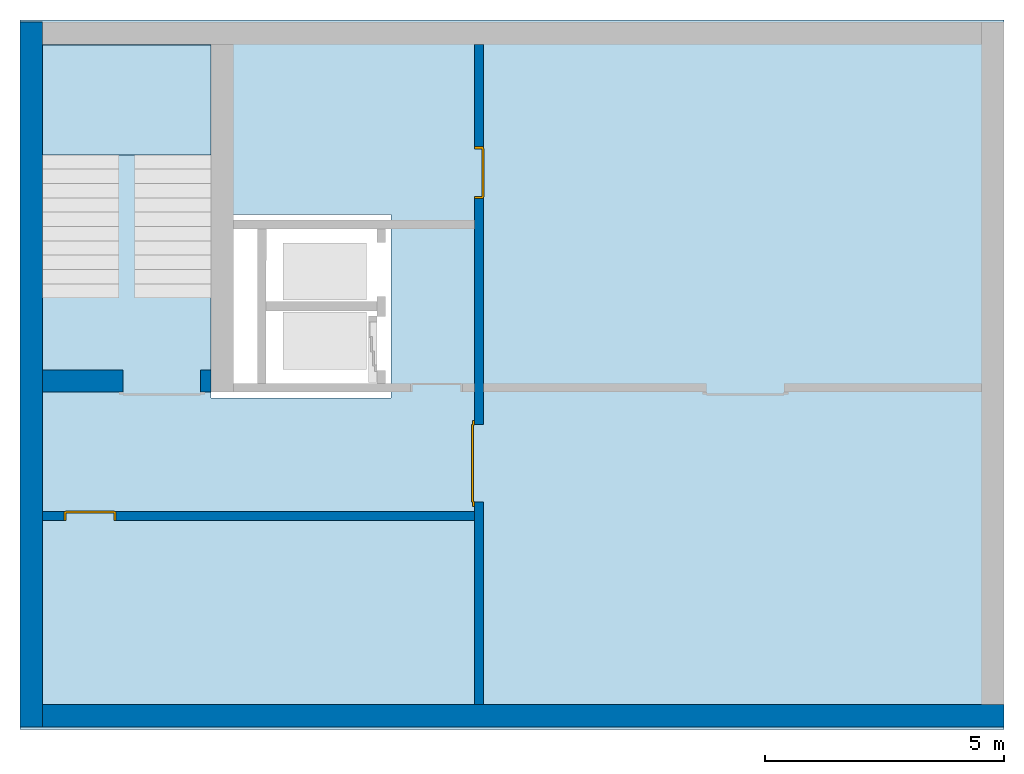
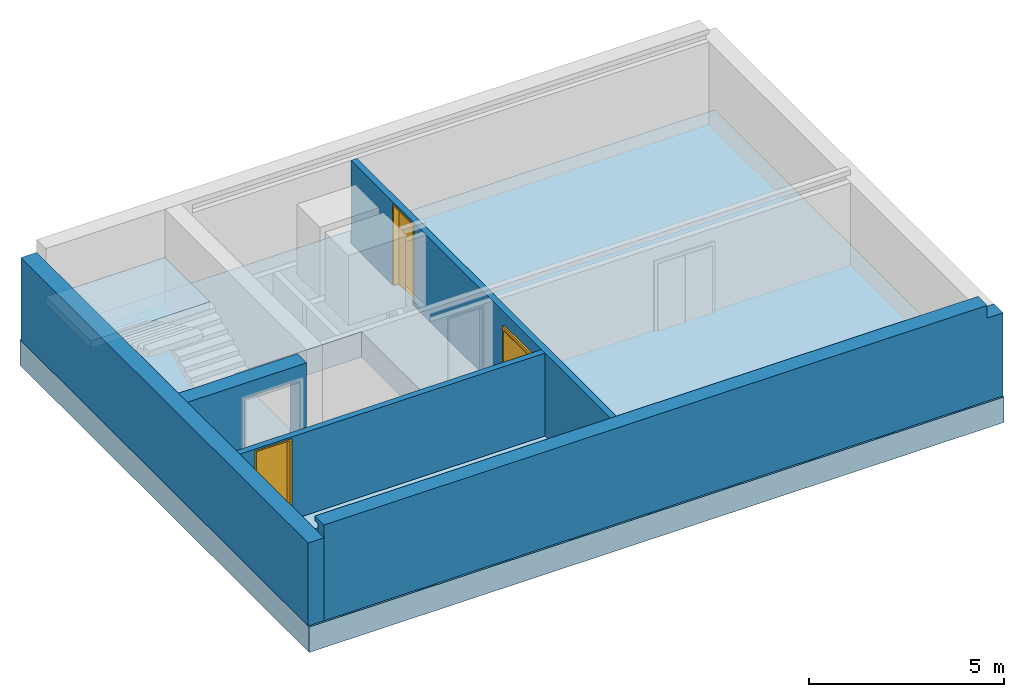
# One storey, part 1 of 5: 5 walls, 3 doors, 1 footing, 1 slab, 4 openings.
"""IFC4 building model written with IfcOpenShell, lengths in metres."""

from ifc_helpers import new_model, entity, si_unit, converted_unit, derived_unit, direction, frame, origin_with_axes, place, context, subcontext, project, spatial, polygons, source, transform, mapped, material, type_object, element, fill, save


model = new_model("IFC4")

# Units and contexts
model_context = context("Model", 3, precision=1e-05, world=origin_with_axes(), true_north=direction((0.0, 1.0)))
body_context = subcontext(model_context, "Body", "Model", "MODEL_VIEW")
ifc_project = project(units=[si_unit("LENGTHUNIT", "METRE"), si_unit("AREAUNIT", "SQUARE_METRE"), si_unit("VOLUMEUNIT", "CUBIC_METRE"), converted_unit("PLANEANGLEUNIT", "DEGREE", entity("IfcPlaneAngleMeasure", 0.0174532925199433), si_unit("PLANEANGLEUNIT", "RADIAN"), dimensions=[0, 0, 0, 0, 0, 0, 0]), converted_unit("TIMEUNIT", "Year", entity("IfcTimeMeasure", 31557600.0), si_unit("TIMEUNIT", "SECOND"), dimensions=[0, 0, 1, 0, 0, 0, 0]), si_unit("MASSUNIT", "GRAM", prefix="KILO"), si_unit("THERMODYNAMICTEMPERATUREUNIT", "DEGREE_CELSIUS"), si_unit("LUMINOUSINTENSITYUNIT", "LUMEN"), si_unit("ENERGYUNIT", "JOULE", prefix="MEGA"), derived_unit("THERMALCONDUCTANCEUNIT", [(si_unit("POWERUNIT", "WATT"), 1), (si_unit("LENGTHUNIT", "METRE"), -1), (si_unit("THERMODYNAMICTEMPERATUREUNIT", "KELVIN"), -1)]), derived_unit("SPECIFICHEATCAPACITYUNIT", [(si_unit("ENERGYUNIT", "JOULE"), 1), (si_unit("MASSUNIT", "GRAM", prefix="KILO"), -1), (si_unit("THERMODYNAMICTEMPERATUREUNIT", "KELVIN"), -1)]), derived_unit("MASSDENSITYUNIT", [(si_unit("MASSUNIT", "GRAM", prefix="KILO"), 1), (si_unit("VOLUMEUNIT", "CUBIC_METRE"), -1)])], contexts=[model_context])

# Site, building, storey
site_placement = place(None, origin_with_axes())
site = spatial("IfcSite", under=ifc_project, at=site_placement, CompositionType="ELEMENT")
building_placement = place(site_placement, origin_with_axes())
building = spatial("IfcBuilding", under=site, at=building_placement, CompositionType="ELEMENT")
storey_placement = place(building_placement, frame((0.0, 0.0, -3.0), z_axis=(0.0, 0.0, 1.0), x_axis=(1.0, 0.0, 0.0)))
storey = spatial("IfcBuildingStorey", under=building, at=storey_placement, Name="UG", CompositionType="ELEMENT", Elevation=-3.0)

# Footing
ifc_material_1 = material(Name="Stahlbeton Decke")
footing_type = type_object("IfcFootingType", Name="Stahlbeton Decke 800", PredefinedType="NOTDEFINED")
footing_placement = place(storey_placement, frame((44.584, 14.84599975347495, 0.0), z_axis=(0.0, 0.0, 1.0), x_axis=(1.0, 0.0, 0.0)))
element("IfcFooting", 1, at=footing_placement, inside=storey, type_object=footing_type, material=ifc_material_1, Name="Decke-001", PredefinedType="NOTDEFINED", context=body_context, shape_type="Tessellation", body=[
    polygons([(0.0, 0.0, 0.0), (0.0, 0.0, -0.7999999999999998), (-20.59599999999999, 0.0, -0.7999999999999998), (-20.59599999999999, 0.0, 0.0), (0.0, -14.84599975347495, 0.0), (0.0, -14.84599975347495, -0.7999999999999998), (-20.59599999999999, -14.84599975347495, -0.7999999999999998), (-12.82599999999999, -4.070999808007393, -0.7999999999999998), (-16.59599990856638, -4.070999808007393, -0.7999999999999998), (-16.59599990856638, -7.910999808007396, -0.7999999999999998), (-12.82599999999999, -7.910999808007396, -0.7999999999999998), (-20.59599999999999, -14.84599975347495, 0.0), (-16.59599990856638, -7.910999808007396, 0.0), (-16.59599990856638, -4.070999808007393, 0.0), (-12.82599999999999, -4.070999808007393, 0.0), (-12.82599999999999, -7.910999808007396, 0.0)], [[[1, 2, 3, 4]], [[5, 6, 2, 1]], [[3, 2, 6, 7], [8, 9, 10, 11]], [[4, 3, 7, 12]], [[5, 1, 4, 12], [13, 14, 15, 16]], [[12, 7, 6, 5]], [[14, 9, 8, 15]], [[13, 10, 9, 14]], [[16, 11, 10, 13]], [[15, 8, 11, 16]]], closed=True),
])

# Slab
ifc_material_2 = material(Name="Stahlbeton")
slab_type = type_object("IfcSlabType", Name="Stahlbeton 220", PredefinedType="LANDING")
slab_placement = place(storey_placement, frame((24.458, 12.02499994546755, 1.500000000000001), z_axis=(0.0, 0.0, 1.0), x_axis=(1.0, 0.0, 0.0)))
element("IfcSlab", 2, at=slab_placement, inside=storey, type_object=slab_type, material=ifc_material_2, Name="Decke-002", PredefinedType="LANDING", context=body_context, shape_type="Tessellation", body=[
    polygons([(0.0, 0.0, 0.0), (0.0, 0.0, -0.22), (3.530000000000001, 0.0, -0.22), (3.530000000000001, 0.0, 0.0), (0.0, 2.300999945467559, 0.0), (0.0, 2.300999945467559, -0.22), (3.530000000000001, 2.300999945467559, -0.22), (3.530000000000001, 2.300999945467559, 0.0)], [[[1, 2, 3, 4]], [[5, 6, 2, 1]], [[3, 2, 6, 7]], [[4, 3, 7, 8]], [[5, 1, 4, 8]], [[8, 7, 6, 5]]], closed=True),
])

# Walls
wall_type_1 = type_object("IfcWallType", Name="Stahlbeton 470", PredefinedType="NOTDEFINED")
wall_1_placement = place(storey_placement, frame((24.458, 0.5199999999999996, 0.0), z_axis=(0.0, 0.0, 1.0), x_axis=(1.0, 0.0, 0.0)))
element("IfcWall", 3, at=wall_1_placement, inside=storey, type_object=wall_type_1, material=ifc_material_2, Name="Wand-002", PredefinedType="NOTDEFINED", context=body_context, shape_type="Tessellation", body=[
    polygons([(19.656, -0.4699999999999989, 2.6), (19.656, -0.1569999999999991, 2.6), (19.656, -0.1569999999999991, 2.85), (19.656, 0.0, 2.85), (19.656, 0.0, 3.0), (19.656, -0.4699999999999989, 3.0), (20.126, 0.0, 2.6), (19.656, 0.0, 2.6), (20.126, -0.4699999999999989, 2.6), (0.0, -0.1569999999999991, 2.85), (0.0, -0.1569999999999991, 2.6), (0.0, 0.0, 2.85), (0.0, 0.0, 3.0), (0.0, -0.4699999999999998, 3.0), (0.0, -0.4699999999999998, 2.6), (0.0, -0.4699999999999998, 0.0), (20.126, -0.4699999999999989, 0.0), (0.0, 0.0, 0.0), (0.0, 0.0, 2.6), (20.126, 0.0, 0.0)], [[[1, 2, 3, 4, 5, 6]], [[7, 8, 2, 1, 9]], [[10, 3, 2, 11]], [[10, 12, 4, 3]], [[5, 4, 12, 13]], [[5, 13, 14, 6]], [[6, 14, 15, 16, 17, 9, 1]], [[18, 19, 8, 7, 20]], [[11, 2, 8, 19]], [[9, 17, 20, 7]], [[12, 10, 11, 15, 14, 13]], [[15, 11, 19, 18, 16]], [[20, 17, 16, 18]]], closed=True),
])
wall_2_placement = place(storey_placement, frame((24.458, 14.33186573724055, 0.0), z_axis=(0.0, 0.0, 1.0), x_axis=(0.0, -1.0, 0.0)))
element("IfcWall", 4, at=wall_2_placement, inside=storey, type_object=wall_type_1, material=ifc_material_2, Name="Wand-001", PredefinedType="NOTDEFINED", context=body_context, shape_type="Tessellation", body=[
    polygons([(14.28186573724055, -0.4699999999999989, 2.6), (14.28186573724055, 0.0, 2.6), (-0.4700000000000006, 0.0, 2.6), (-0.4699999999999989, -0.4699999999999989, 2.6), (14.28186573724055, -0.4699999999999989, 0.0), (14.28186573724055, 0.0, 0.0), (-0.4700000000000006, 0.0, 0.0), (-0.4699999999999989, -0.4699999999999989, 0.0)], [[[1, 2, 3, 4]], [[2, 1, 5, 6]], [[2, 6, 7, 3]], [[8, 4, 3, 7]], [[5, 1, 4, 8]], [[6, 5, 8, 7]]], closed=True),
])

# Wall, opening
wall_3_placement = place(storey_placement, frame((27.988, 7.054999945467554, 0.0), z_axis=(0.0, 0.0, 1.0), x_axis=(-1.0, 0.0, 0.0)))
wall_3 = element("IfcWall", 5, at=wall_3_placement, inside=storey, type_object=wall_type_1, material=ifc_material_2, Name="Wand-001", PredefinedType="NOTDEFINED", context=body_context, shape_type="Tessellation", body=[
    polygons([(1.839999999999996, -0.4700000000000006, 2.11), (1.839999999999996, -0.4699999999999998, 0.0), (3.530000000000001, -0.4700000000000006, 0.0), (3.530000000000001, -0.4699999999999998, 2.600000000000001), (0.0, -0.4699999999999998, 2.600000000000001), (0.0, -0.4699999999999998, 0.0), (0.2199999999999989, -0.4699999999999998, 0.0), (0.2199999999999989, -0.4700000000000006, 2.11), (1.839999999999996, 0.0, 2.11), (1.839999999999996, 0.0, 0.0), (3.530000000000001, 0.0, 0.0), (3.530000000000001, 0.0, 2.600000000000001), (0.0, 0.0, 2.600000000000001), (0.0, 0.0, 0.0), (0.2199999999999989, 0.0, 0.0), (0.2199999999999989, 0.0, 2.11)], [[[1, 2, 3, 4, 5, 6, 7, 8]], [[2, 1, 9, 10]], [[2, 10, 11, 3]], [[4, 3, 11, 12]], [[12, 13, 5, 4]], [[5, 13, 14, 6]], [[15, 7, 6, 14]], [[8, 7, 15, 16]], [[1, 8, 16, 9]], [[16, 15, 14, 13, 12, 11, 10, 9]]], closed=True),
])
opening_1_placement = place(wall_3_placement, frame((1.029999999999998, 0.0, 0.0), z_axis=(0.0, 0.0, 1.0), x_axis=(1.0, 0.0, 0.0)))
element("IfcOpeningElement", 6, at=opening_1_placement, cuts=wall_3, context=body_context, identifier="Reference", shape_type="Tessellation", body=[
    polygons([(-0.8099999999999987, -0.4710000000000001, 2.11), (-0.8099999999999987, -0.4710000000000001, 0.0), (0.8099999999999987, -0.4710000000000001, 0.0), (0.8099999999999987, -0.4710000000000001, 2.11), (-0.8099999999999987, 0.001000000000000334, 2.11), (-0.8099999999999987, 0.001000000000000334, 0.0), (0.8099999999999987, 0.001000000000000334, 0.0), (0.8099999999999987, 0.001000000000000334, 2.11)], [[[1, 2, 3, 4]], [[5, 6, 2, 1]], [[6, 7, 3, 2]], [[7, 8, 4, 3]], [[8, 5, 1, 4]], [[7, 6, 5, 8]]], closed=True),
])

# Wall, openings, doors
wall_type_2 = type_object("IfcWallType", Name="Stahlbeton 180", PredefinedType="NOTDEFINED")
wall_4_placement = place(storey_placement, frame((33.505, 14.33186573724055, 0.0), z_axis=(0.0, 0.0, 1.0), x_axis=(0.0, -1.0, 0.0)))
wall_4 = element("IfcWall", 7, at=wall_4_placement, inside=storey, type_object=wall_type_2, material=ifc_material_2, Name="Wand-001", PredefinedType="NOTDEFINED", context=body_context, shape_type="Tessellation", body=[
    polygons([(3.226865791772994, 0.1799999999999997, 0.0), (3.226865791772994, 0.1799999999999997, 2.545), (2.136865791772994, 0.1799999999999997, 2.545), (2.136865791772994, 0.1799999999999997, 0.0), (0.0, 0.1799999999999997, 0.0), (0.0, 0.1799999999999997, 2.599999999999998), (13.81186573724055, 0.1799999999999997, 2.599999999999998), (13.81186573724055, 0.1799999999999997, 0.0), (9.576865791772994, 0.1799999999999997, 0.0), (9.576865791772994, 0.1799999999999997, 2.11), (7.956865791772993, 0.1799999999999997, 2.11), (7.956865791772993, 0.1799999999999997, 0.0), (3.226865791772994, 0.0, 0.0), (3.226865791772994, 0.0, 2.545), (2.136865791772994, 0.0, 2.545), (2.136865791772994, 0.0, 0.0), (0.0, 0.0, 0.0), (0.0, 0.0, 2.599999999999998), (13.81186573724055, 0.0, 2.599999999999998), (13.81186573724055, 0.0, 0.0), (9.576865791772994, 0.0, 0.0), (9.576865791772994, 0.0, 2.11), (7.956865791772993, 0.0, 2.11), (7.956865791772993, 0.0, 0.0)], [[[1, 2, 3, 4, 5, 6, 7, 8, 9, 10, 11, 12]], [[2, 1, 13, 14]], [[3, 2, 14, 15]], [[4, 3, 15, 16]], [[4, 16, 17, 5]], [[17, 18, 6, 5]], [[6, 18, 19, 7]], [[7, 19, 20, 8]], [[9, 8, 20, 21]], [[9, 21, 22, 10]], [[10, 22, 23, 11]], [[11, 23, 24, 12]], [[13, 1, 12, 24]], [[14, 13, 24, 23, 22, 21, 20, 19, 18, 17, 16, 15]]], closed=True),
])
opening_2_placement = place(wall_4_placement, frame((8.766865791772993, 0.0, 0.0), z_axis=(0.0, 0.0, 1.0), x_axis=(1.0, 0.0, 0.0)))
opening_2 = element("IfcOpeningElement", 8, at=opening_2_placement, cuts=wall_4, context=body_context, identifier="Reference", shape_type="Tessellation", body=[
    polygons([(0.8100000000000005, 0.1809999999999974, 2.110000000000002), (0.8100000000000005, 0.1809999999999974, 0.0), (-0.8100000000000005, 0.1809999999999974, 0.0), (-0.8100000000000005, 0.1809999999999974, 2.110000000000002), (0.8100000000000005, -0.0009999999999976694, 2.110000000000002), (0.8100000000000005, -0.0009999999999976694, 0.0), (-0.8100000000000005, -0.0009999999999976694, 0.0), (-0.8100000000000005, -0.0009999999999976694, 2.110000000000002)], [[[1, 2, 3, 4]], [[5, 6, 2, 1]], [[6, 7, 3, 2]], [[7, 8, 4, 3]], [[8, 5, 1, 4]], [[7, 6, 5, 8]]], closed=True),
])
opening_3_placement = place(wall_4_placement, frame((2.681865791772994, 0.0, 0.0), z_axis=(0.0, 0.0, 1.0), x_axis=(1.0, 0.0, 0.0)))
opening_3 = element("IfcOpeningElement", 9, at=opening_3_placement, cuts=wall_4, context=body_context, identifier="Reference", shape_type="Tessellation", body=[
    polygons([(-0.5449999999999999, -0.0009999999999976694, 2.545000000000001), (-0.5449999999999999, -0.0009999999999976694, 0.0), (0.5449999999999999, -0.0009999999999976694, 0.0), (0.5449999999999999, -0.0009999999999976694, 2.545000000000001), (-0.5449999999999999, 0.1809999999999974, 2.545000000000001), (-0.5449999999999999, 0.1809999999999974, 0.0), (0.5449999999999999, 0.1809999999999974, 0.0), (0.5449999999999999, 0.1809999999999974, 2.545000000000001)], [[[1, 2, 3, 4]], [[5, 6, 2, 1]], [[6, 7, 3, 2]], [[7, 8, 4, 3]], [[8, 5, 1, 4]], [[7, 6, 5, 8]]], closed=True),
])
door_type_1 = type_object("IfcDoorType", OperationType="DOUBLE_DOOR_SINGLE_SWING", PredefinedType="DOOR")
shared_shape = source(origin_with_axes(), body_context, "Body", "Tessellation", [
    polygons([(-0.9000000000000001, 0.0, 0.0), (-0.9000000000000001, 0.0, 2.2), (-0.9000000000000001, 0.03, 2.2), (-0.9000000000000001, 0.03, 0.0), (-0.8000000000000002, 0.0, 0.0), (-0.8000000000000002, 0.0, 2.1), (-0.1101, 0.0, 2.1), (-0.0001, 0.0, 2.1), (0.8000000000000002, 0.0, 2.1), (0.8000000000000002, 0.0, 0.0), (0.9000000000000001, 0.0, 0.0), (0.9000000000000001, 0.0, 2.2), (0.9000000000000001, 0.03, 2.2), (0.9000000000000001, 0.03, 0.0), (0.8000000000000002, 0.03, 0.0), (0.8000000000000002, 0.03, 2.1), (-0.0001, 0.03, 2.1), (-0.1101, 0.03, 2.1), (-0.8000000000000002, 0.03, 2.1), (-0.8000000000000002, 0.03, 0.0)], [[[1, 2, 3, 4]], [[1, 5, 6, 7, 8, 9, 10, 11, 12, 2]], [[2, 12, 13, 3]], [[4, 3, 13, 14, 15, 16, 17, 18, 19, 20]], [[5, 1, 4, 20]], [[6, 5, 20, 19]], [[7, 6, 19, 18]], [[8, 7, 18, 17]], [[9, 8, 17, 16]], [[10, 9, 16, 15]], [[11, 10, 15, 14]], [[12, 11, 14, 13]]], closed=True),
    polygons([(-0.9000000000000001, 0.03, 0.0), (-0.9000000000000001, 0.03, 2.2), (-0.9000000000000001, 0.05, 2.2), (-0.9000000000000001, 0.05, 0.0), (-0.8100000000000002, 0.03, 0.0), (-0.8100000000000002, 0.03, 2.11), (-0.1001, 0.03, 2.11), (-0.0101, 0.03, 2.11), (0.8100000000000002, 0.03, 2.11), (0.8100000000000002, 0.03, 0.0), (0.9000000000000001, 0.03, 0.0), (0.9000000000000001, 0.03, 2.2), (0.9000000000000001, 0.05, 2.2), (0.9000000000000001, 0.05, 0.0), (0.8100000000000002, 0.05, 0.0), (0.8100000000000002, 0.05, 2.11), (-0.0101, 0.05, 2.11), (-0.1001, 0.05, 2.11), (-0.8100000000000002, 0.05, 2.11), (-0.8100000000000002, 0.05, 0.0)], [[[1, 2, 3, 4]], [[1, 5, 6, 7, 8, 9, 10, 11, 12, 2]], [[2, 12, 13, 3]], [[4, 3, 13, 14, 15, 16, 17, 18, 19, 20]], [[5, 1, 4, 20]], [[6, 5, 20, 19]], [[7, 6, 19, 18]], [[8, 7, 18, 17]], [[9, 8, 17, 16]], [[10, 9, 16, 15]], [[11, 10, 15, 14]], [[12, 11, 14, 13]]], closed=True),
    polygons([(-0.81, 0.07, 0.0), (-0.81, 0.07, 2.11), (-0.0004999999999999449, 0.07, 2.11), (-0.0004999999999999449, 0.07, 0.0), (-0.81, 0.03000000000000001, 0.0), (-0.81, 0.03000000000000001, 2.11), (-0.0004999999999999449, 0.03000000000000001, 2.11), (-0.0004999999999999449, 0.03000000000000001, 0.0)], [[[1, 2, 3, 4]], [[1, 5, 6, 2]], [[2, 6, 7, 3]], [[3, 7, 8, 4]], [[4, 8, 5, 1]], [[8, 7, 6, 5]]], closed=True),
    polygons([(0.81, 0.07, 0.0), (0.0004999999999999449, 0.07, 0.0), (0.0004999999999999449, 0.07, 2.11), (0.81, 0.07, 2.11), (0.81, 0.03000000000000001, 0.0), (0.0004999999999999449, 0.03000000000000001, 0.0), (0.0004999999999999449, 0.03000000000000001, 2.11), (0.81, 0.03000000000000001, 2.11)], [[[1, 2, 3, 4]], [[2, 1, 5, 6]], [[3, 2, 6, 7]], [[4, 3, 7, 8]], [[1, 4, 8, 5]], [[6, 5, 8, 7]]], closed=True),
])
door_1_placement = place(opening_2_placement, frame((0.7999999999999998, 0.0, 0.0), z_axis=(0.0, 0.0, 1.0), x_axis=(-1.0, 0.0, 0.0)))
door_1 = element("IfcDoor", 10, at=door_1_placement, inside=storey, type_object=door_type_1, OverallHeight=2.11, OverallWidth=1.62, PredefinedType="DOOR", context=body_context, shape_type="MappedRepresentation", body=[
    mapped(shared_shape, transform((0.7999999999999998, 0.0, 0.0))),
])
fill(opening_2, door_1)
door_type_2 = type_object("IfcDoorType", Name="27", OperationType="SINGLE_SWING_LEFT", PredefinedType="DOOR")
door_2_placement = place(opening_3_placement, frame((-0.5, 0.0, 0.0), z_axis=(0.0, 0.0, 1.0), x_axis=(1.0, 0.0, 0.0)))
door_2 = element("IfcDoor", 11, at=door_2_placement, inside=storey, type_object=door_type_2, OverallHeight=2.545, OverallWidth=1.09, PredefinedType="DOOR", context=body_context, shape_type="Tessellation", body=[
    polygons([(-0.04499999999999993, 0.0, 0.0), (-0.04499999999999993, 0.0, 2.545000000000001), (-0.04499999999999993, 0.1550000000000011, 2.545000000000001), (-0.04499999999999993, 0.1550000000000011, 0.0), (0.0, 0.0, 0.0), (0.0, 0.0, 2.500000000000001), (0.4449000000000005, 0.0, 2.500000000000001), (0.4999000000000002, 0.0, 2.500000000000001), (1.0, 0.0, 2.500000000000001), (1.0, 0.0, 0.0), (1.045, 0.0, 0.0), (1.045, 0.0, 2.545000000000001), (1.045, 0.1550000000000011, 2.545000000000001), (1.045, 0.1550000000000011, 0.0), (1.0, 0.1550000000000011, 0.0), (1.0, 0.1550000000000011, 2.500000000000001), (0.4999000000000002, 0.1550000000000011, 2.500000000000001), (0.4449000000000005, 0.1550000000000011, 2.500000000000001), (0.0, 0.1550000000000011, 2.500000000000001), (0.0, 0.1550000000000011, 0.0)], [[[1, 2, 3, 4]], [[1, 5, 6, 7, 8, 9, 10, 11, 12, 2]], [[2, 12, 13, 3]], [[4, 3, 13, 14, 15, 16, 17, 18, 19, 20]], [[5, 1, 4, 20]], [[6, 5, 20, 19]], [[7, 6, 19, 18]], [[8, 7, 18, 17]], [[9, 8, 17, 16]], [[10, 9, 16, 15]], [[11, 10, 15, 14]], [[12, 11, 14, 13]]], closed=True),
    polygons([(-0.04499999999999993, 0.1550000000000011, 0.0), (-0.04499999999999993, 0.1550000000000011, 2.545000000000001), (-0.04499999999999993, 0.1799999999999997, 2.545000000000001), (-0.04499999999999993, 0.1799999999999997, 0.0), (-0.009999999999999787, 0.1550000000000011, 0.0), (-0.009999999999999787, 0.1550000000000011, 2.510000000000001), (0.4549000000000003, 0.1550000000000011, 2.510000000000001), (0.4899000000000004, 0.1550000000000011, 2.510000000000001), (1.01, 0.1550000000000011, 2.510000000000001), (1.01, 0.1550000000000011, 0.0), (1.045, 0.1550000000000011, 0.0), (1.045, 0.1550000000000011, 2.545000000000001), (1.045, 0.1799999999999997, 2.545000000000001), (1.045, 0.1799999999999997, 0.0), (1.01, 0.1799999999999997, 0.0), (1.01, 0.1799999999999997, 2.510000000000001), (0.4899000000000004, 0.1799999999999997, 2.510000000000001), (0.4549000000000003, 0.1799999999999997, 2.510000000000001), (-0.009999999999999787, 0.1799999999999997, 2.510000000000001), (-0.009999999999999787, 0.1799999999999997, 0.0)], [[[1, 2, 3, 4]], [[1, 5, 6, 7, 8, 9, 10, 11, 12, 2]], [[2, 12, 13, 3]], [[4, 3, 13, 14, 15, 16, 17, 18, 19, 20]], [[5, 1, 4, 20]], [[6, 5, 20, 19]], [[7, 6, 19, 18]], [[8, 7, 18, 17]], [[9, 8, 17, 16]], [[10, 9, 16, 15]], [[11, 10, 15, 14]], [[12, 11, 14, 13]]], closed=True),
    polygons([(-0.009999999999999787, 0.1950000000000003, 0.0), (-0.009999999999999787, 0.1950000000000003, 2.510000000000001), (1.01, 0.1950000000000003, 2.510000000000001), (1.01, 0.1950000000000003, 0.0), (-0.009999999999999787, 0.1550000000000011, 0.0), (-0.009999999999999787, 0.1550000000000011, 2.510000000000001), (1.01, 0.1550000000000011, 2.510000000000001), (1.01, 0.1550000000000011, 0.0)], [[[1, 2, 3, 4]], [[1, 5, 6, 2]], [[2, 6, 7, 3]], [[3, 7, 8, 4]], [[4, 8, 5, 1]], [[8, 7, 6, 5]]], closed=True),
])
fill(opening_3, door_2)

# Wall, opening, door
wall_5_placement = place(storey_placement, frame((33.505, 4.554999945467554, 0.0), z_axis=(0.0, 0.0, 1.0), x_axis=(-1.0, 0.0, 0.0)))
wall_5 = element("IfcWall", 12, at=wall_5_placement, inside=storey, type_object=wall_type_2, material=ifc_material_2, Name="Wand-003", PredefinedType="NOTDEFINED", context=body_context, shape_type="Tessellation", body=[
    polygons([(8.596999999999994, 0.0, 2.545), (8.596999999999994, 0.0, 0.0), (9.046999999999997, 0.0, 0.0), (9.046999999999997, 0.0, 2.599999999999999), (0.0, 0.0, 2.599999999999999), (0.0, 0.0, 0.0), (7.506999999999998, 0.0, 0.0), (7.506999999999998, 0.0, 2.545), (8.596999999999994, 0.1799999999999997, 2.545), (8.596999999999994, 0.1799999999999997, 0.0), (9.046999999999997, 0.1799999999999997, 0.0), (9.046999999999997, 0.1799999999999997, 2.599999999999999), (0.0, 0.1800000000000006, 2.599999999999999), (0.0, 0.1799999999999997, 0.0), (7.506999999999998, 0.1799999999999997, 0.0), (7.506999999999998, 0.1799999999999997, 2.545)], [[[1, 2, 3, 4, 5, 6, 7, 8]], [[2, 1, 9, 10]], [[2, 10, 11, 3]], [[11, 12, 4, 3]], [[12, 13, 5, 4]], [[14, 6, 5, 13]], [[15, 7, 6, 14]], [[8, 7, 15, 16]], [[1, 8, 16, 9]], [[16, 15, 14, 13, 12, 11, 10, 9]]], closed=True),
])
opening_4_placement = place(wall_5_placement, frame((8.051999999999996, 0.0, 0.0), z_axis=(0.0, 0.0, 1.0), x_axis=(1.0, 0.0, 0.0)))
opening_4 = element("IfcOpeningElement", 13, at=opening_4_placement, cuts=wall_5, context=body_context, identifier="Reference", shape_type="Tessellation", body=[
    polygons([(-0.5449999999999982, -0.001000000000000334, 2.545000000000001), (-0.5449999999999982, -0.001000000000000334, 0.0), (0.5449999999999982, -0.001000000000000334, 0.0), (0.5449999999999982, -0.001000000000000334, 2.545000000000001), (-0.5449999999999982, 0.181, 2.545000000000001), (-0.5449999999999982, 0.181, 0.0), (0.5449999999999982, 0.181, 0.0), (0.5449999999999982, 0.181, 2.545000000000001)], [[[1, 2, 3, 4]], [[5, 6, 2, 1]], [[6, 7, 3, 2]], [[7, 8, 4, 3]], [[8, 5, 1, 4]], [[7, 6, 5, 8]]], closed=True),
])
door_3_placement = place(opening_4_placement, frame((0.5, 0.0, 0.0), z_axis=(0.0, 0.0, 1.0), x_axis=(-1.0, 0.0, 0.0)))
door_3 = element("IfcDoor", 14, at=door_3_placement, inside=storey, type_object=door_type_2, OverallHeight=2.545, OverallWidth=1.09, PredefinedType="DOOR", context=body_context, shape_type="Tessellation", body=[
    polygons([(-0.04499999999999815, -0.1799999999999988, 0.0), (-0.04499999999999815, -0.1799999999999988, 2.545000000000001), (-0.04499999999999815, -0.02499999999999947, 2.545000000000001), (-0.04499999999999815, -0.02499999999999858, 0.0), (0.0, -0.1799999999999988, 0.0), (0.0, -0.1799999999999988, 2.500000000000001), (0.4449000000000005, -0.1799999999999988, 2.500000000000001), (0.4999000000000002, -0.1799999999999988, 2.500000000000001), (1.0, -0.1799999999999997, 2.500000000000001), (1.0, -0.1799999999999988, 0.0), (1.044999999999998, -0.1799999999999988, 0.0), (1.044999999999998, -0.1799999999999997, 2.545000000000001), (1.044999999999998, -0.02499999999999947, 2.545000000000001), (1.044999999999998, -0.02499999999999947, 0.0), (1.0, -0.02499999999999947, 0.0), (1.0, -0.02499999999999947, 2.500000000000001), (0.4999000000000002, -0.02499999999999947, 2.500000000000001), (0.4449000000000005, -0.02499999999999947, 2.500000000000001), (0.0, -0.02499999999999947, 2.500000000000001), (0.0, -0.02499999999999858, 0.0)], [[[1, 2, 3, 4]], [[1, 5, 6, 7, 8, 9, 10, 11, 12, 2]], [[2, 12, 13, 3]], [[4, 3, 13, 14, 15, 16, 17, 18, 19, 20]], [[5, 1, 4, 20]], [[6, 5, 20, 19]], [[7, 6, 19, 18]], [[8, 7, 18, 17]], [[9, 8, 17, 16]], [[10, 9, 16, 15]], [[11, 10, 15, 14]], [[12, 11, 14, 13]]], closed=True),
    polygons([(-0.04499999999999815, -0.02499999999999858, 0.0), (-0.04499999999999815, -0.02499999999999947, 2.545000000000001), (-0.04499999999999815, 0.0, 2.545000000000001), (-0.04499999999999815, 0.0, 0.0), (-0.01000000000000156, -0.02499999999999858, 0.0), (-0.01000000000000156, -0.02499999999999947, 2.510000000000001), (0.4548999999999985, -0.02499999999999947, 2.510000000000001), (0.4898999999999987, -0.02499999999999947, 2.510000000000001), (1.010000000000002, -0.02499999999999947, 2.510000000000001), (1.010000000000002, -0.02499999999999947, 0.0), (1.044999999999998, -0.02499999999999947, 0.0), (1.044999999999998, -0.02499999999999947, 2.545000000000001), (1.044999999999998, 0.0, 2.545000000000001), (1.044999999999998, 0.0, 0.0), (1.010000000000002, 0.0, 0.0), (1.010000000000002, 0.0, 2.510000000000001), (0.4898999999999987, 0.0, 2.510000000000001), (0.4548999999999985, 0.0, 2.510000000000001), (-0.01000000000000156, 0.0, 2.510000000000001), (-0.01000000000000156, 0.0, 0.0)], [[[1, 2, 3, 4]], [[1, 5, 6, 7, 8, 9, 10, 11, 12, 2]], [[2, 12, 13, 3]], [[4, 3, 13, 14, 15, 16, 17, 18, 19, 20]], [[5, 1, 4, 20]], [[6, 5, 20, 19]], [[7, 6, 19, 18]], [[8, 7, 18, 17]], [[9, 8, 17, 16]], [[10, 9, 16, 15]], [[11, 10, 15, 14]], [[12, 11, 14, 13]]], closed=True),
    polygons([(-0.01000000000000156, 0.01500000000000146, 0.0), (-0.01000000000000156, 0.01500000000000057, 2.510000000000001), (1.010000000000002, 0.01500000000000057, 2.510000000000001), (1.010000000000002, 0.01500000000000057, 0.0), (-0.01000000000000156, -0.02499999999999858, 0.0), (-0.01000000000000156, -0.02499999999999947, 2.510000000000001), (1.010000000000002, -0.02499999999999947, 2.510000000000001), (1.010000000000002, -0.02499999999999947, 0.0)], [[[1, 2, 3, 4]], [[1, 5, 6, 2]], [[2, 6, 7, 3]], [[3, 7, 8, 4]], [[4, 8, 5, 1]], [[8, 7, 6, 5]]], closed=True),
])
fill(opening_4, door_3)

save(model, "model.ifc")
